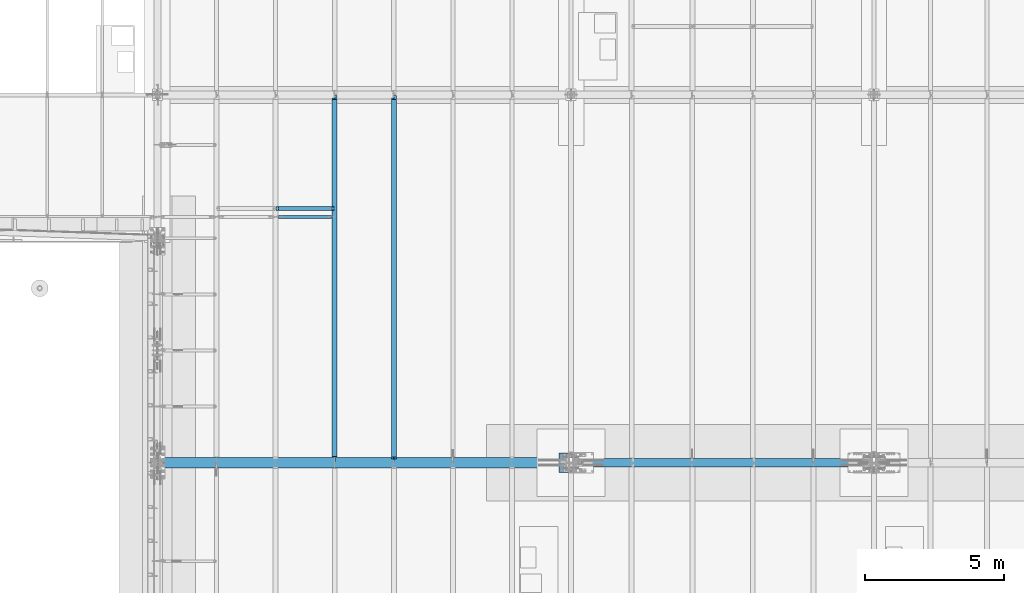
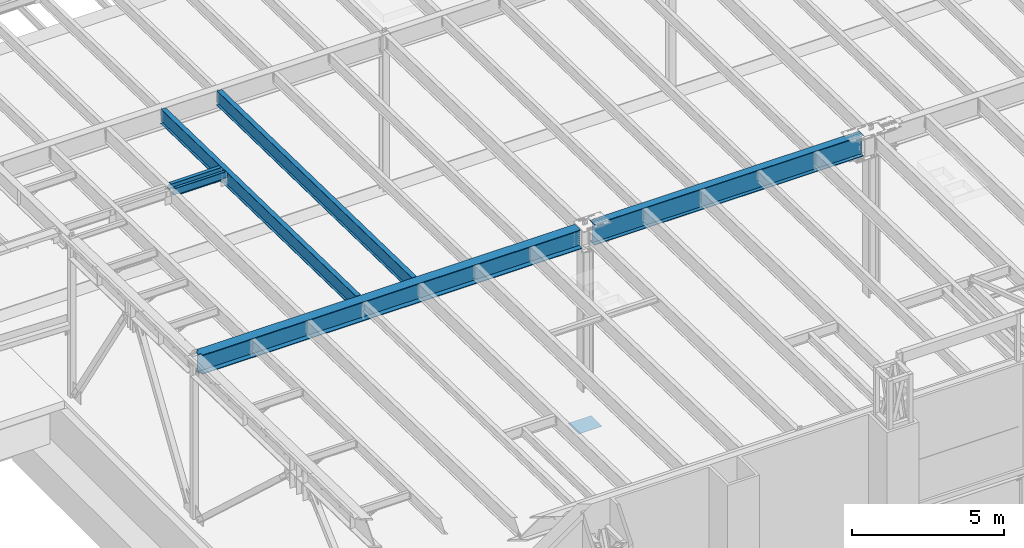
# One storey, part 1050 of 1763: 7 beams, 7 elements without a shape of their own.
"""IFC2X3 building model written with IfcOpenShell, lengths in millimetres."""

from ifc_helpers import new_model, si_unit, frame, origin_with_axes, place, context, subcontext, project, spatial, faceted_brep, material, type_object, element, aggregate, save


model = new_model("IFC2X3")

# Units and contexts
model_context = context("Model", 3, precision=1e-05, world=origin_with_axes())
body_context = subcontext(model_context, "Body", "Model", "MODEL_VIEW")
ifc_project = project(units=[si_unit("LENGTHUNIT", "METRE", prefix="MILLI"), si_unit("AREAUNIT", "SQUARE_METRE"), si_unit("VOLUMEUNIT", "CUBIC_METRE"), si_unit("MASSUNIT", "GRAM", prefix="KILO"), si_unit("TIMEUNIT", "SECOND"), si_unit("PLANEANGLEUNIT", "RADIAN"), si_unit("SOLIDANGLEUNIT", "STERADIAN"), si_unit("THERMODYNAMICTEMPERATUREUNIT", "DEGREE_CELSIUS"), si_unit("LUMINOUSINTENSITYUNIT", "LUMEN")], contexts=[model_context])

# Site, building, storey
site_placement = place(None, origin_with_axes())
site = spatial("IfcSite", under=ifc_project, at=site_placement, CompositionType="ELEMENT")
building_placement = place(site_placement, origin_with_axes())
building = spatial("IfcBuilding", under=site, at=building_placement, Name="Undefined", CompositionType="ELEMENT")
storey_placement = place(building_placement, origin_with_axes())
storey = spatial("IfcBuildingStorey", under=building, at=storey_placement, Name="Undefined", CompositionType="ELEMENT", Elevation=0.0)

# Assembly, beam
assembly_1_placement = place(storey_placement, origin_with_axes())
assembly_1 = element("IfcElementAssembly", 1, at=assembly_1_placement, inside=storey, Name="BEAM", AssemblyPlace="NOTDEFINED", PredefinedType="RIGID_FRAME")
ifc_material_1 = material(Name="STEEL/A992")
beam_type_1 = type_object("IfcBeamType", Name="W8X18", PredefinedType="NOTDEFINED")
beam_1_placement = place(assembly_1_placement, frame((-83122.7515594126, 9601.2, 11614.0449111666), z_axis=(0.0, 0.0, 1.0), x_axis=(1.0, 0.0, 0.0)))
beam_1 = element("IfcBeam", 2, at=beam_1_placement, type_object=beam_type_1, material=ifc_material_1, Name="BEAM", ObjectType="W8X18", context=body_context, shape_type="Brep", body=[
    faceted_brep([(87.3125001907465, -3.17499999999927, 66.4150016680069), (87.3125001907465, 3.17499999999927, 66.4150016680069), (17.4625000000087, 3.17499999999927, 66.4150016680069), (17.4625000000087, -3.17499999999927, 66.4150016680069), (92.1725797087856, -3.17499999999927, 67.3817315905944), (92.1725797087856, 3.17499999999927, 67.3817315905944), (96.2927561769466, -3.17499999999927, 70.134745491072), (96.2927561769466, 3.17499999999927, 70.134745491072), (99.0457700774277, -3.17499999999927, 74.2549219592256), (99.0457700774277, 3.17499999999927, 74.2549219592256), (100.012500000012, -3.17499999999927, 79.115001477272), (100.012500000012, 3.17499999999927, 79.115001477272), (100.012500000012, -66.6749999999993, 103.11874512049), (100.012500000001, 66.6749999999993, 103.1875), (100.012500000001, 66.6749999999993, 95.25), (100.012500000001, 3.17499999999927, 95.25), (100.012500000001, -3.17499999999927, 95.25), (100.012500000001, -66.6749999999993, 95.25), (17.4624999999905, -3.17500000000018, -95.25), (17.4624999999905, -66.6750000000002, -95.25), (2108.88035714286, -66.6750000000002, -95.25), (2108.88035714286, -3.17500000000018, -95.25), (17.4624999999905, -66.6750000000002, -103.1875), (2108.88035714286, -66.6750000000002, -103.1875), (17.4624999999905, 66.6750000000002, -103.1875), (2108.88035714286, 66.6750000000002, -103.1875), (17.4624999999905, 66.6750000000002, -95.25), (2108.88035714286, 66.6750000000002, -95.25), (17.4624999999905, 3.17500000000018, -95.25), (2108.88035714286, 3.17500000000018, -95.25), (2108.88035714287, 3.17499999999927, 66.4150016740186), (2108.88035714287, -3.17499999999927, 66.4150016740186), (2039.03035695213, 3.17499999999927, 66.4150016740186), (2039.03035695213, -3.17499999999927, 66.4150016740186), (2034.1702774341, 3.17499999999927, 67.3817315966062), (2034.1702774341, -3.17499999999927, 67.3817315966062), (2030.05010096593, 3.17499999999927, 70.1347454970837), (2030.05010096593, -3.17499999999927, 70.1347454970837), (2027.29708706545, 3.17499999999927, 74.2549219652374), (2027.29708706545, -3.17499999999927, 74.2549219652374), (2026.33035714287, 3.17499999999927, 79.1150014832838), (2026.33035714287, -3.17499999999927, 79.1150014832838), (2026.33035714287, -66.6749999999993, 103.1875), (2026.33035714287, -66.6749999999993, 95.25), (2026.33035714287, -3.17499999999927, 95.25), (2026.33035714287, 3.17499999999927, 95.25), (2026.33035714287, 66.6749999999993, 95.25), (2026.33035714287, 66.6749999999993, 103.1875)], [[[0, 1, 2, 3]], [[4, 5, 1, 0]], [[6, 7, 5, 4]], [[8, 9, 7, 6]], [[10, 11, 9, 8]], [[12, 13, 14, 15, 11, 10, 16, 17]], [[18, 19, 20, 21]], [[19, 22, 23, 20]], [[22, 24, 25, 23]], [[24, 26, 27, 25]], [[26, 28, 29, 27]], [[21, 20, 23, 25, 27, 29, 30, 31]], [[31, 30, 32, 33]], [[33, 32, 34, 35]], [[35, 34, 36, 37]], [[37, 36, 38, 39]], [[39, 38, 40, 41]], [[42, 43, 44, 41, 40, 45, 46, 47]], [[43, 42, 12, 17]], [[44, 43, 17, 16]], [[8, 6, 4, 0, 3, 18, 21, 31, 33, 35, 37, 39, 41, 44, 16, 10]], [[28, 26, 24, 22, 19, 18, 3, 2]], [[45, 40, 38, 36, 34, 32, 30, 29, 28, 2, 1, 5, 7, 9, 11, 15]], [[46, 45, 15, 14]], [[47, 46, 14, 13]], [[42, 47, 13, 12]]]),
])
aggregate(assembly_1, [beam_1])

assembly_2_placement = place(storey_placement, origin_with_axes())
assembly_2 = element("IfcElementAssembly", 3, at=assembly_2_placement, inside=storey, Name="BEAM", AssemblyPlace="NOTDEFINED", PredefinedType="RIGID_FRAME")
beam_type_2 = type_object("IfcBeamType", Name="W12X22", PredefinedType="NOTDEFINED")
beam_2_placement = place(assembly_2_placement, frame((-83122.7515594126, 9296.39999999999, 11568.0295365109), z_axis=(0.0, 0.0, 1.0), x_axis=(1.0, 0.0, 0.0)))
beam_2 = element("IfcBeam", 4, at=beam_2_placement, type_object=beam_type_2, material=ifc_material_1, Name="BEAM", ObjectType="W12X22", context=body_context, shape_type="Brep", body=[
    faceted_brep([(17.4625000000087, -3.17499999999927, -130.175000004278), (17.4625000000087, 3.17499999999927, -130.175000004278), (271.462500190726, 3.17500002404267, -130.175000004278), (271.462500190726, -3.17499999999927, -130.175000004278), (276.322579708765, 3.17500002418637, -131.141729926865), (276.322579708765, -3.17499999999927, -131.141729926865), (280.442756176926, 3.17500002459201, -133.894743827343), (280.442756176926, -3.17499999999927, -133.894743827343), (283.195770077407, 3.17500002519773, -138.014920295496), (283.195770077407, -3.17499999999927, -138.014920295496), (284.162499999991, -3.17499999999927, -142.874999813543), (284.162499999991, 3.17500002591078, -142.874999813543), (284.162499999991, 3.17500009460491, -144.4625), (284.162499999991, 50.7999999999993, -144.4625), (284.162499999991, 50.7999999999993, -155.575000000001), (284.162499999991, -50.7999999999993, -155.575000000001), (284.162499999991, -50.7999999999993, -144.4625), (284.162499999991, -3.17499999999927, -144.4625), (2013.63035714286, 50.7999999999993, 144.4625), (2013.63035714286, 3.17499999999927, 144.4625), (112.712499999994, 3.17499999999927, 144.4625), (112.712499999994, 50.7999999999993, 144.4625), (100.012500190729, -3.17499999999927, 130.174999995723), (100.012500190729, 3.1749999863805, 130.174999995723), (17.4625000000087, 3.17499999999927, 130.174999995723), (17.4625000000087, -3.17499999999927, 130.174999995723), (104.872579708768, -3.17499999999927, 131.14172991831), (104.872579708768, 3.17499998624044, 131.14172991831), (108.992756176929, -3.17499999999927, 133.894743818788), (108.992756176929, 3.17499998584026, 133.894743818788), (111.74577007741, -3.17499999999927, 138.014920286942), (111.74577007741, 3.17499998524181, 138.014920286942), (112.712499999994, -3.17499999999927, 142.874999804988), (112.712499999994, 3.17499998453604, 142.874999804988), (2013.63035714286, -50.7999999999993, 155.575000000001), (2013.63035714286, 50.7999999999993, 155.575000000001), (112.712499999994, 50.7999999999993, 155.575000000001), (112.712499999994, -50.7999999999993, 155.575000000001), (2013.63035714286, -50.7999999999993, 144.4625), (112.712499999994, -50.7999999999993, 144.4625), (2013.63035714286, -3.17499999999927, 144.4625), (112.712499999994, -3.17499999999927, 144.4625), (2013.63035714286, -3.17499999999927, 142.874999804988), (2013.63035714286, 3.17499999999927, 142.874999804988), (2014.59708706544, -3.17499999999927, 138.014920286942), (2014.59708706544, 3.17499999999927, 138.014920286942), (2017.35010096592, -3.17499999999927, 133.894743818788), (2017.35010096592, 3.17499999999927, 133.894743818788), (2021.47027743408, -3.17499999999927, 131.14172991831), (2021.47027743408, 3.17499999999927, 131.14172991831), (2026.33035695212, -3.17499999999927, 130.174999995723), (2026.33035695212, 3.17499999999927, 130.174999995723), (2108.88035714287, -3.17499999999927, 130.174999995723), (2108.88035714287, 3.17499999999927, 130.174999995723), (2108.88035714287, -3.17499999999927, -130.175000004278), (2108.88035714287, 3.17499999999927, -130.175000004278), (1854.88035695213, -3.17499999999927, -130.175000004278), (1854.88035695213, 3.17499999999927, -130.175000004278), (1850.02027743409, -3.17499999999927, -131.141729926865), (1850.02027743409, 3.17499999999927, -131.141729926865), (1845.90010096593, -3.17499999999927, -133.894743827343), (1845.90010096593, 3.17499999999927, -133.894743827343), (1843.14708706544, -3.17499999999927, -138.014920295496), (1843.14708706544, 3.17499999999927, -138.014920295496), (1842.18035714286, -3.17499999999927, -142.874999813543), (1842.18035714286, 3.17499999999927, -142.874999813543), (1842.18035714286, -3.17499999999927, -144.4625), (1842.18035714286, -50.7999999999993, -144.4625), (1842.18035714286, -50.7999999999993, -155.575000000001), (1842.18035714286, 50.7999999999993, -155.575000000001), (1842.18035714286, 50.7999999999993, -144.4625), (1842.18035714286, 3.17499999999927, -144.4625)], [[[0, 1, 2, 3]], [[3, 2, 4, 5]], [[5, 4, 6, 7]], [[7, 6, 8, 9]], [[10, 11, 12, 13, 14, 15, 16, 17]], [[9, 8, 11, 10]], [[18, 19, 20, 21]], [[22, 23, 24, 25]], [[26, 27, 23, 22]], [[28, 29, 27, 26]], [[30, 31, 29, 28]], [[32, 33, 31, 30]], [[34, 35, 36, 37]], [[38, 34, 37, 39]], [[40, 38, 39, 41]], [[37, 36, 21, 20, 33, 32, 41, 39]], [[35, 18, 21, 36]], [[34, 38, 40, 42, 43, 19, 18, 35]], [[44, 45, 43, 42]], [[46, 47, 45, 44]], [[48, 49, 47, 46]], [[50, 51, 49, 48]], [[52, 53, 51, 50]], [[53, 52, 54, 55]], [[54, 56, 57, 55]], [[58, 59, 57, 56]], [[60, 61, 59, 58]], [[62, 63, 61, 60]], [[64, 65, 63, 62]], [[66, 67, 68, 69, 70, 71, 65, 64]], [[67, 66, 17, 16]], [[68, 67, 16, 15]], [[69, 68, 15, 14]], [[70, 69, 14, 13]], [[71, 70, 13, 12]], [[6, 4, 2, 1, 24, 23, 27, 29, 31, 33, 20, 19, 43, 45, 47, 49, 51, 53, 55, 57, 59, 61, 63, 65, 71, 12, 11, 8]], [[25, 24, 1, 0]], [[66, 64, 62, 60, 58, 56, 54, 52, 50, 48, 46, 44, 42, 40, 41, 32, 30, 28, 26, 22, 25, 0, 3, 5, 7, 9, 10, 17]]]),
])
aggregate(assembly_2, [beam_2])

assembly_3_placement = place(storey_placement, origin_with_axes())
assembly_3 = element("IfcElementAssembly", 5, at=assembly_3_placement, inside=storey, Name="BEAM", AssemblyPlace="NOTDEFINED", PredefinedType="RIGID_FRAME")
beam_type_3 = type_object("IfcBeamType", Name="W24X55", PredefinedType="NOTDEFINED")
beam_3_placement = place(assembly_3_placement, frame((-78870.0658451269, 450.92880941152, 11608.424216848), z_axis=(0.0, 0.0209013539966291, 0.999781542838788), x_axis=(0.0, 0.999781542776098, -0.0209013569953182)))
beam_3 = element("IfcBeam", 6, at=beam_3_placement, type_object=beam_type_3, material=ifc_material_1, Name="BEAM", ObjectType="W24X55", context=body_context, shape_type="Brep", body=[
    faceted_brep([(32.9216259333548, -5.06265067245113, -287.33750000024), (33.1871311560335, -5.06238327905885, -300.03750000025), (153.914585386825, -5.0623648079054, -300.037500000291), (153.914585386861, -5.06263216065418, -287.33750000028), (153.914598213893, -88.8999999999942, -287.33750000028), (153.914598213888, -88.8999999999942, -300.037500000291), (204.714570270236, -4.76249999999709, 248.977497673244), (204.714570270236, 4.76249999999709, 248.977497673244), (203.747840347651, 4.76249999999709, 244.117418155187), (203.747840347651, -4.76249999999709, 244.117418155187), (200.994826447175, 4.76249999999709, 239.997241687024), (200.994826447175, -4.76249999999709, 239.997241687024), (196.874649979021, 4.76249999999709, 237.244227786541), (196.874649979021, -4.76249999999709, 237.244227786541), (192.014570460975, 4.76249999999709, 236.277497863954), (192.014570460975, -4.76249999999709, 236.277497863954), (21.9749710825074, 4.76249999999709, 236.277497863952), (21.9749710825074, -4.76249999999709, 236.277497863952), (32.9216259333548, -4.76249999999709, -287.33750000024), (13228.7230938096, -4.76249999999709, -287.337500004809), (13217.3781810464, -4.76249999999709, 255.32750160553), (13083.0160379566, -4.76249999999709, 255.327501605576), (13078.1559584386, -4.76249999999709, 256.294231528167), (13074.0357819704, -4.76249999999709, 259.047245428657), (13071.2827680699, -4.76249999999709, 263.167421896822), (13070.3160381474, -4.76249999999709, 268.027501414879), (13070.3160381473, -4.76249999999709, 287.337499995707), (204.714570270192, -4.76249999999709, 287.33750000016), (13217.3781810464, 4.76249999999709, 255.32750160553), (13083.0160379566, 4.76249999999709, 255.327501605576), (13078.1559584386, 4.76249999999709, 256.294231528167), (13074.0357819704, 4.76249999999709, 259.047245428657), (13071.2827680699, 4.76249999999709, 263.167421896822), (13070.3160381474, 4.76249999999709, 268.027501414879), (13070.3160381473, -88.8999999999942, 300.037499995717), (13070.3160381473, -88.8999999999942, 287.337499995707), (13070.3160381473, 4.76249999999709, 287.337499995707), (13070.3160381473, 88.8999999999942, 287.337499995707), (13070.3160381473, 88.8999999999942, 300.037499995717), (204.714570270192, 4.76249999999709, 287.33750000016), (204.714570270192, 88.8999999999942, 287.33750000016), (204.714570270192, 88.8999999999942, 300.03750000017), (204.714570270192, -88.8999999999942, 300.03750000017), (204.714570270192, -88.8999999999942, 287.33750000016), (13228.7230938096, 4.76249999999709, -287.337500004809), (32.9216259333548, 4.76249999999709, -287.33750000024), (13127.4660345771, 5.0626322090975, -287.337500004771), (13127.4660345772, 5.06236486541457, -300.037500004782), (13127.4660261933, 88.8999999999942, -300.037500004782), (13127.4660261934, 88.8999999999942, -287.337500004771), (153.914571035813, 88.8999999999942, -300.037500000291), (153.914571035818, 88.8999999999942, -287.337500000282), (153.914583862354, 5.06263212728663, -300.037500000293), (153.914583862389, 5.06236477453785, -287.33750000028), (33.1871311560335, 5.06261365597311, -300.03750000025), (32.9216259333548, 5.06234626258083, -287.33750000024), (13228.7230938096, 5.06264233497495, -287.337500004809), (13228.9885990323, 5.06237501776195, -300.037500004817), (13228.7230938096, -88.8999999999942, -287.337500004809), (13228.9885990323, -88.8999999999942, -300.037500004817)], [[[0, 1, 2, 3]], [[4, 3, 2, 5]], [[6, 7, 8, 9]], [[9, 8, 10, 11]], [[11, 10, 12, 13]], [[13, 12, 14, 15]], [[15, 14, 16, 17]], [[9, 11, 13, 15, 17, 18, 19, 20, 21, 22, 23, 24, 25, 26, 27, 6]], [[20, 28, 29, 21]], [[21, 29, 30, 22]], [[22, 30, 31, 23]], [[23, 31, 32, 24]], [[24, 32, 33, 25]], [[34, 35, 26, 25, 33, 36, 37, 38]], [[37, 36, 39, 40]], [[38, 37, 40, 41]], [[34, 38, 41, 42]], [[35, 34, 42, 43]], [[26, 35, 43, 27]], [[42, 41, 40, 39, 7, 6, 27, 43]], [[36, 33, 32, 31, 30, 29, 28, 44, 45, 16, 14, 12, 10, 8, 7, 39]], [[46, 47, 48, 49]], [[49, 48, 50, 51]], [[51, 50, 52, 53]], [[53, 52, 54, 55]], [[45, 44, 56, 46, 49, 51, 53, 55]], [[57, 47, 46, 56]], [[44, 28, 20, 19, 58, 59, 57, 56]], [[59, 58, 4, 5]], [[1, 54, 52, 50, 48, 47, 57, 59, 5, 2]], [[18, 17, 16, 45, 55, 54, 1, 0]], [[58, 19, 18, 0, 3, 4]]]),
])
aggregate(assembly_3, [beam_3])

assembly_4_placement = place(storey_placement, origin_with_axes())
assembly_4 = element("IfcElementAssembly", 7, at=assembly_4_placement, inside=storey, Name="BEAM", AssemblyPlace="NOTDEFINED", PredefinedType="RIGID_FRAME")
beam_4_placement = place(assembly_4_placement, frame((-80996.4087022698, 450.92880941152, 11608.424216848), z_axis=(0.0, 0.0209013539966291, 0.999781542838788), x_axis=(0.0, 0.999781542776098, -0.0209013569953182)))
beam_4 = element("IfcBeam", 8, at=beam_4_placement, type_object=beam_type_3, material=ifc_material_1, Name="BEAM", ObjectType="W24X55", context=body_context, shape_type="Brep", body=[
    faceted_brep([(222.141409579197, -4.76174993514724, -300.037500000315), (221.87590435652, -4.76249999999709, -287.337500000305), (32.9216259333548, -4.76249999999709, -287.33750000024), (33.1871311560335, -4.76174993514724, -300.03750000025), (222.141409579011, -88.8999999999942, -300.037500000315), (221.875904356335, -88.8999999999942, -287.337500000303), (13070.3160381473, -88.8999999999942, 300.037499995717), (13070.3160381473, -88.8999999999942, 287.337499995707), (13070.3160381473, -4.76249999999709, 287.337499995707), (13070.3160381474, -4.76249999999709, 268.027501414879), (13070.3160381474, 4.76249999999709, 268.027501414879), (13070.3160381473, 4.76249999999709, 287.337499995707), (13070.3160381473, 88.8999999999942, 287.337499995707), (13070.3160381473, 88.8999999999942, 300.037499995717), (13071.2827680699, -4.76249999999709, 263.167421896822), (13071.2827680699, 4.76249999999709, 263.167421896822), (13074.0357819704, -4.76249999999709, 259.047245428657), (13074.0357819704, 4.76249999999709, 259.047245428657), (13078.1559584386, -4.76249999999709, 256.294231528167), (13078.1559584386, 4.76249999999709, 256.294231528167), (13083.0160379566, -4.76249999999709, 255.327501605576), (13083.0160379566, 4.76249999999709, 255.327501605576), (13217.3781810464, -4.76249999999709, 255.32750160553), (13217.3781810464, 4.76249999999709, 255.32750160553), (13200.3922765104, 5.0625, -287.337500004798), (13128.7205653613, 5.0625, -288.835863282578), (13128.6892406939, 5.0625, -287.337500004773), (33.1871311560335, 4.76299991607084, -300.03750000025), (32.9216259333548, 4.76249999999709, -287.33750000024), (221.87590435652, 4.76249999999709, -287.337500000305), (222.141409579197, 4.76299991607084, -300.037500000315), (13127.4660345771, 5.0626322090975, -287.337500004771), (13127.4660345772, 5.06236486541457, -300.037500004782), (13127.4660261933, 88.8999999999942, -300.037500004782), (13127.4660261934, 88.8999999999942, -287.337500004771), (222.141409579011, 88.8999999999942, -300.037500000315), (221.875904356335, 88.8999999999942, -287.337500000303), (13228.7230938096, 4.76249999999709, -287.337500004809), (13228.7230938096, 5.06264233497495, -287.337500004809), (13228.9885990323, 5.06237501776195, -300.037500004817), (13228.7230938096, -4.76249999999709, -287.337500004809), (13228.7230938096, -88.8999999999942, -287.337500004809), (13228.9885990323, -88.8999999999942, -300.037500004817), (21.8699710393521, -4.76249999999709, 241.300000000139), (21.8699710393521, 4.76249999999709, 241.300000000139), (204.792009575198, -4.76249999999709, 241.300000000141), (204.792009575198, 4.76249999999709, 241.300000000141), (209.652089093244, -4.76249999999709, 242.266729922727), (209.652089093244, 4.76249999999709, 242.266729922727), (210.788169300356, -4.76249999999709, 243.025834448084), (213.772265561397, -4.76249999999709, 245.019743823212), (213.772265561397, 4.76249999999709, 245.019743823212), (216.525279461874, -4.76249999999709, 249.139920291376), (216.525279461874, 4.76249999999709, 249.139920291376), (217.492009384458, -4.76249999999709, 253.999999809434), (217.492009384458, 4.76249999999709, 253.999999809434), (217.492009384419, 4.76249999999709, 287.337500000156), (217.492009384419, 88.8999999999942, 287.337500000156), (217.492009384418, 88.8999999999942, 300.037500000166), (217.492009384418, -88.8999999999942, 300.037500000166), (217.492009384419, -88.8999999999942, 287.337500000156), (217.492009384419, -4.76249999999709, 287.337500000156)], [[[0, 1, 2, 3]], [[4, 5, 1, 0]], [[6, 7, 8, 9, 10, 11, 12, 13]], [[14, 15, 10, 9]], [[16, 17, 15, 14]], [[18, 19, 17, 16]], [[20, 21, 19, 18]], [[22, 23, 21, 20]], [[24, 25, 26]], [[27, 28, 29, 30]], [[31, 32, 33, 34]], [[34, 33, 35, 36]], [[30, 29, 36, 35]], [[37, 38, 24, 26, 31, 34, 36, 29]], [[39, 32, 31, 26, 25, 24, 38]], [[37, 23, 22, 40, 41, 42, 39, 38]], [[3, 27, 30, 35, 33, 32, 39, 42, 4, 0]], [[43, 44, 28, 27, 3, 2]], [[45, 46, 44, 43]], [[47, 48, 46, 45]], [[49, 50, 51, 48, 47]], [[52, 53, 51, 50]], [[54, 55, 53, 52]], [[11, 10, 15, 17, 19, 21, 23, 37, 29, 28, 44, 46, 48, 51, 53, 55, 56]], [[12, 11, 56, 57]], [[13, 12, 57, 58]], [[6, 13, 58, 59]], [[7, 6, 59, 60]], [[8, 7, 60, 61]], [[59, 58, 57, 56, 55, 54, 61, 60]], [[52, 50, 49, 47, 45, 43, 2, 1, 40, 22, 20, 18, 16, 14, 9, 8, 61, 54]], [[41, 40, 1, 5]], [[42, 41, 5, 4]]]),
])
aggregate(assembly_4, [beam_4])

assembly_5_placement = place(storey_placement, origin_with_axes())
assembly_5 = element("IfcElementAssembly", 9, at=assembly_5_placement, inside=storey, Name="TEMPLATE", AssemblyPlace="NOTDEFINED", PredefinedType="RIGID_FRAME")
ifc_material_2 = material(Name="STEEL/A36")
beam_type_4 = type_object("IfcBeamType", PredefinedType="NOTDEFINED")
beam_5_placement = place(assembly_5_placement, frame((-72046.5372736972, 457.200000000843, 3851.275), z_axis=(0.0, -1.0, 0.0), x_axis=(-1.0, 0.0, 0.0)))
beam_5 = element("IfcBeam", 10, at=beam_5_placement, type_object=beam_type_4, material=ifc_material_2, Name="TEMPLATE", context=body_context, shape_type="Brep", body=[
    faceted_brep([(0.0, 3.17500000000018, -355.599999999999), (0.0, 3.17500000000018, 355.599999999999), (889.0, 3.17500000000018, 355.599999999999), (889.0, 3.17500000000018, -355.599999999999), (0.0, -3.17500000000018, 355.599999999999), (889.0, -3.17500000000018, 355.599999999999), (0.0, -3.17500000000018, -355.599999999999), (889.0, -3.17500000000018, -355.599999999999)], [[[0, 1, 2, 3]], [[1, 4, 5, 2]], [[4, 6, 7, 5]], [[6, 0, 3, 7]], [[5, 7, 3, 2]], [[6, 4, 1, 0]]]),
])
aggregate(assembly_5, [beam_5])

assembly_6_placement = place(storey_placement, origin_with_axes())
assembly_6 = element("IfcElementAssembly", 11, at=assembly_6_placement, inside=storey, Name="BEAM", AssemblyPlace="NOTDEFINED", PredefinedType="RIGID_FRAME")
beam_type_5 = type_object("IfcBeamType", Name="W33X130", PredefinedType="NOTDEFINED")
beam_6_placement = place(assembly_6_placement, frame((-72491.0372736984, 457.200000000003, 11487.7086714953), z_axis=(0.0, 0.0, 1.0), x_axis=(1.0, 0.0, 0.0)))
beam_6 = element("IfcBeam", 12, at=beam_6_placement, type_object=beam_type_5, material=ifc_material_1, Name="BEAM", ObjectType="W33X130", context=body_context, shape_type="Brep", body=[
    faceted_brep([(10515.5999999997, 41.2749999999983, -398.4625), (10371.1375032422, 41.2749999999983, -398.4625), (10371.1375032422, 41.2749999999983, -420.6875), (10515.5999999997, 41.2749999999983, -420.6875), (10366.8849335271, 40.4291112905111, -398.4625), (10366.8849335271, 40.4291112905111, -420.6875), (10363.2797790014, 38.0202240500688, -398.4625), (10363.2797790014, 38.0202240500688, -420.6875), (10360.870891761, 34.4150695244115, -398.4625), (10360.870891761, 34.4150695244115, -420.6875), (10360.0250030515, 30.1624998092634, -398.4625), (10360.0250030515, 30.1624998092634, -420.6875), (10360.870891761, 25.9099300941153, -398.4625), (10360.870891761, 25.9099300941153, -420.6875), (10363.2797790014, 22.304775568458, -398.4625), (10363.2797790014, 22.304775568458, -420.6875), (10366.8849335271, 19.8958883280157, -398.4625), (10366.8849335271, 19.8958883280157, -420.6875), (10371.1375032422, 19.0499996185285, -398.4625), (10371.1375032422, 19.0499996185285, -420.6875), (10515.5999999997, 19.0499996185285, -398.4625), (10515.5999999997, 19.0499996185285, -420.6875), (263.525000001115, 146.05, -420.6875), (263.525000001115, 146.05, -398.4625), (10515.5999999997, 146.05, -398.4625), (10515.5999999997, 146.05, -420.6875), (263.525000001115, 42.0683913107273, -420.6875), (263.525000001115, 42.0683913107273, -398.4625), (407.987496758622, 42.0683913107273, -420.6875), (407.987496758622, 42.0683913107273, -398.4625), (412.240066473765, 41.2225026012401, -420.6875), (412.240066473765, 41.2225026012401, -398.4625), (415.845220999428, 38.8136153607978, -420.6875), (415.845220999428, 38.8136153607978, -398.4625), (418.254108239867, 35.2084608351406, -420.6875), (418.254108239867, 35.2084608351406, -398.4625), (419.099996949357, 30.9558911199924, -420.6875), (419.099996949357, 30.9558911199924, -398.4625), (418.254108239867, 26.7033214048443, -420.6875), (418.254108239867, 26.7033214048443, -398.4625), (415.845220999428, 23.098166879187, -420.6875), (415.845220999428, 23.098166879187, -398.4625), (412.240066473765, 20.6892796387447, -420.6875), (412.240066473765, 20.6892796387447, -398.4625), (407.987496758622, 19.8433909292576, -420.6875), (407.987496758622, 19.8433909292576, -398.4625), (263.525000001115, 19.8433909292576, -420.6875), (263.525000001115, 19.8433909292576, -398.4625), (263.525000001115, -146.05, -420.6875), (263.525000001115, -146.05, -398.4625), (263.525000001115, -7.14375000000001, -398.4625), (263.525000001115, -7.14375000000001, 398.4625), (263.525000001115, -146.05, 398.4625), (263.525000001115, -146.05, 420.6875), (263.525000001115, 146.05, 420.6875), (263.525000001115, 146.05, 398.4625), (263.525000001115, 7.14375000000001, 398.4625), (263.525000001115, 7.14375000000001, -398.4625), (10515.5999999997, -146.05, -420.6875), (10515.5999999997, -146.05, -398.4625), (10515.5999999997, -7.14375000000001, -398.4625), (10515.5999999997, -7.14375000000001, 398.4625), (10515.5999999997, -146.05, 398.4625), (10515.5999999997, -146.05, 420.6875), (10515.5999999997, 146.05, 420.6875), (10515.5999999997, 146.05, 398.4625), (10515.5999999997, 7.14375000000001, 398.4625), (10515.5999999997, 7.14375000000001, -398.4625)], [[[0, 1, 2, 3]], [[4, 5, 2, 1]], [[6, 7, 5, 4]], [[8, 9, 7, 6]], [[10, 11, 9, 8]], [[12, 13, 11, 10]], [[14, 15, 13, 12]], [[16, 17, 15, 14]], [[18, 19, 17, 16]], [[20, 21, 19, 18]], [[22, 23, 24, 25]], [[23, 22, 26, 27]], [[27, 26, 28, 29]], [[29, 28, 30, 31]], [[31, 30, 32, 33]], [[33, 32, 34, 35]], [[35, 34, 36, 37]], [[37, 36, 38, 39]], [[39, 38, 40, 41]], [[41, 40, 42, 43]], [[43, 42, 44, 45]], [[45, 44, 46, 47]], [[48, 49, 50, 51, 52, 53, 54, 55, 56, 57, 47, 46]], [[49, 48, 58, 59]], [[50, 49, 59, 60]], [[51, 50, 60, 61]], [[52, 51, 61, 62]], [[53, 52, 62, 63]], [[54, 53, 63, 64]], [[55, 54, 64, 65]], [[56, 55, 65, 66]], [[57, 56, 66, 67]], [[16, 14, 12, 10, 8, 6, 4, 1, 0, 24, 23, 27, 29, 31, 33, 35, 37, 39, 41, 43, 45, 47, 57, 67, 20, 18]], [[25, 24, 0, 3]], [[58, 48, 46, 44, 42, 40, 38, 36, 34, 32, 30, 28, 26, 22, 25, 3, 2, 5, 7, 9, 11, 13, 15, 17, 19, 21]], [[67, 66, 65, 64, 63, 62, 61, 60, 59, 58, 21, 20]]]),
])
aggregate(assembly_6, [beam_6])

assembly_7_placement = place(storey_placement, origin_with_axes())
assembly_7 = element("IfcElementAssembly", 13, at=assembly_7_placement, inside=storey, Name="BEAM", AssemblyPlace="NOTDEFINED", PredefinedType="RIGID_FRAME")
beam_type_6 = type_object("IfcBeamType", Name="W30X173", PredefinedType="NOTDEFINED")
beam_7_placement = place(assembly_7_placement, frame((-87375.4372736983, 457.200000000026, 11521.0461714953), z_axis=(0.0, 0.0, 1.0), x_axis=(1.0, 0.0, 0.0)))
beam_7 = element("IfcBeam", 14, at=beam_7_placement, type_object=beam_type_6, material=ifc_material_1, Name="BEAM", ObjectType="W30X173", context=body_context, shape_type="Brep", body=[
    faceted_brep([(203.199998474127, 190.5, -360.362499999999), (203.199998474127, 190.5, -387.35), (203.199998474127, 88.9000015258862, -387.35), (203.199998474127, 88.9000015258862, -360.362499999999), (14671.6750000011, 190.5, -360.362499999999), (14671.6750000011, 190.5, -387.35), (14671.6750000011, -7.9375, -360.062501525879), (14671.6750000011, -7.9375, -360.362499999999), (14671.6750000011, -190.5, -360.362499999999), (14671.6750000011, -190.5, -387.35), (14671.6750000011, 7.9375, -360.362499999999), (14671.6750000011, 7.9375, -360.062501525879), (14671.6750000011, 7.9375, 336.290001678466), (14671.6750000011, -7.9375, 336.290001678466), (114.300000000003, 7.9375, -360.362499999999), (114.300000000003, 7.9375, 360.362499999999), (14608.1750000011, 7.9375, 360.362499999999), (14608.1750000011, 7.9375, 348.990001487731), (14609.1417299237, 7.9375, 344.129921969685), (14611.8947438242, 7.9375, 340.009745501531), (14616.0149202923, 7.9375, 337.256731601054), (14620.8749998104, 7.9375, 336.290001678466), (203.199998474127, 190.5, 387.35), (203.199998474127, 190.5, 360.362499999999), (203.199998474127, 88.9000015258862, 360.362499999999), (203.199998474127, 88.9000015258862, 387.35), (114.300000000003, 88.9000015258862, 360.362499999999), (14608.1750000011, 190.5, 360.362499999999), (114.300000000003, 88.9000015258862, 387.35), (203.199998474127, -190.499999999994, 387.35), (203.199998474127, -88.9000015258862, 387.35), (203.199998474127, -88.9000015258862, 360.362499999999), (203.199998474127, -190.5, 360.362499999999), (114.300000000003, -88.9000015258862, 387.35), (114.300000000003, -88.9000015258862, 360.362499999999), (114.300000000003, -7.9375, 360.362499999999), (14608.1750000011, -7.9375, 360.362499999999), (14608.1750000011, -190.5, 360.362499999999), (14608.1750000011, -190.5, 387.35), (14608.1750000011, 190.5, 387.35), (14608.1750000011, -7.9375, 348.990001487731), (14609.1417299237, -7.9375, 344.129921969685), (14611.8947438242, -7.9375, 340.009745501531), (14616.0149202923, -7.9375, 337.256731601054), (14620.8749998104, -7.9375, 336.290001678466), (114.300000000003, -7.9375, -360.362499999999), (114.300000000003, -88.9000015258862, -360.362499999999), (203.199998474127, -88.9000015258862, -360.362499999999), (203.199998474127, -190.499999999994, -360.362499999999), (203.199998474127, -190.5, -387.35), (114.300000000003, -88.9000015258862, -387.35), (114.300000000003, 88.9000015258862, -387.35), (203.199998474127, -88.9000015258862, -387.35), (114.300000000003, 88.9000015258862, -360.362499999999)], [[[0, 1, 2, 3]], [[4, 5, 1, 0]], [[6, 7, 8, 9, 5, 4, 10, 11, 12, 13]], [[11, 10, 14, 15, 16, 17, 18, 19, 20, 21, 12]], [[22, 23, 24, 25]], [[15, 26, 24, 23, 27, 16]], [[25, 24, 26, 28]], [[29, 30, 31, 32]], [[33, 34, 31, 30]], [[32, 31, 34, 35, 36, 37]], [[29, 32, 37, 38]], [[22, 25, 28, 33, 30, 29, 38, 39]], [[23, 22, 39, 27]], [[38, 37, 36, 40, 17, 16, 27, 39]], [[41, 18, 17, 40]], [[42, 19, 18, 41]], [[43, 20, 19, 42]], [[44, 21, 20, 43]], [[13, 12, 21, 44]], [[43, 42, 41, 40, 36, 35, 45, 7, 6, 13, 44]], [[8, 7, 45, 46, 47, 48]], [[9, 8, 48, 49]], [[50, 51, 2, 1, 5, 9, 49, 52]], [[48, 47, 52, 49]], [[46, 50, 52, 47]], [[45, 35, 34, 33, 28, 26, 15, 14, 53, 51, 50, 46]], [[3, 2, 51, 53]], [[14, 10, 4, 0, 3, 53]]]),
])
aggregate(assembly_7, [beam_7])

save(model, "model.ifc")
